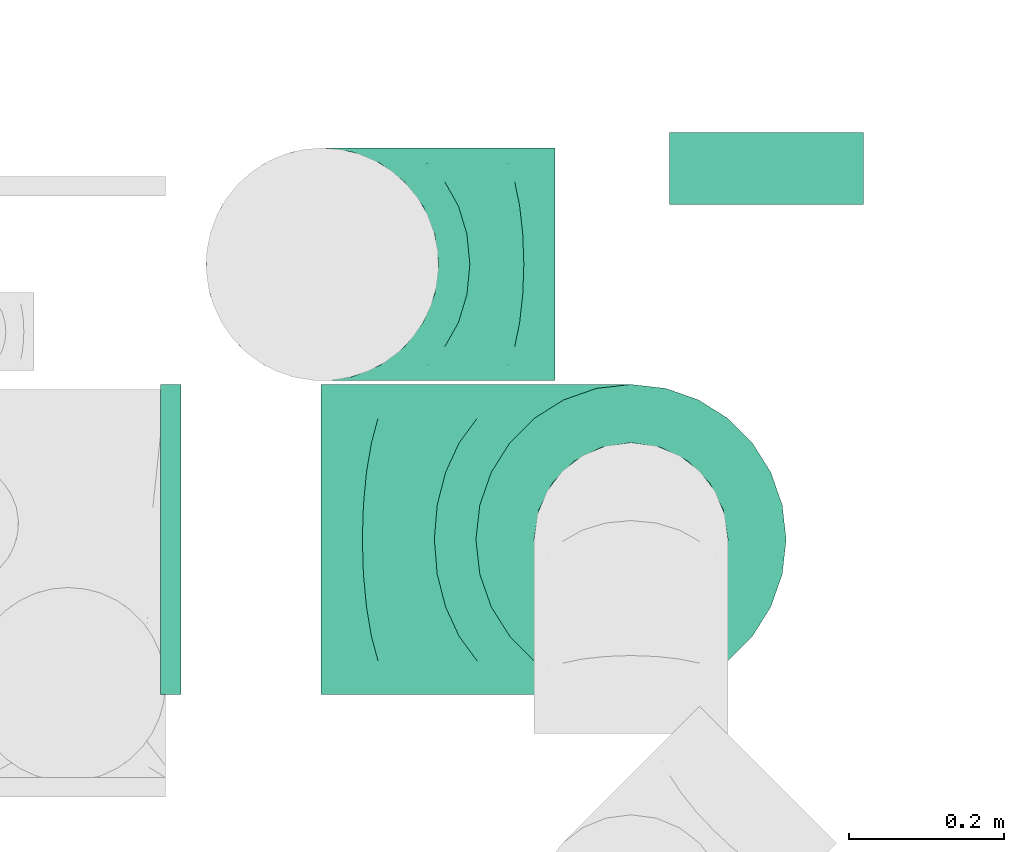
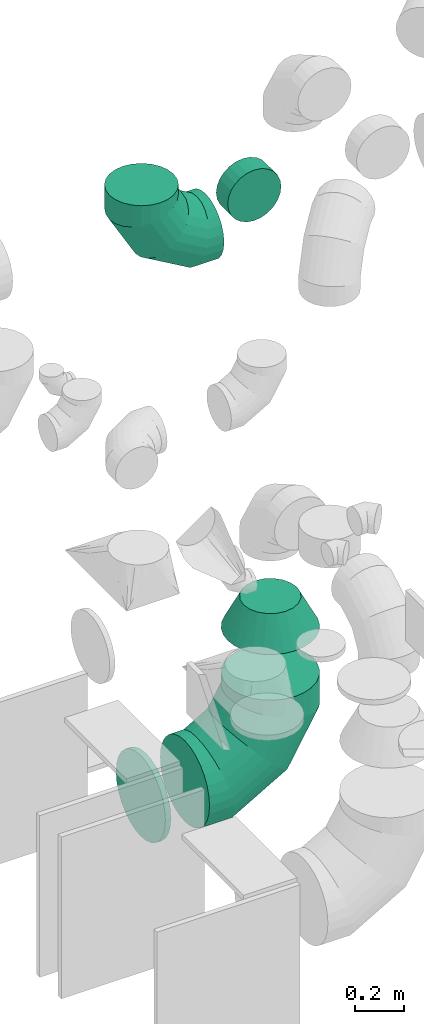
# One storey, part 34 of 59: 5 flow fittings.
"""IFC2X3 building model written with IfcOpenShell, lengths in millimetres."""

from ifc_helpers import new_model, entity, si_unit, converted_unit, derived_unit, direction, frame, origin, place, context, subcontext, project, spatial, faceted_brep, source, transform, mapped, material, type_object, type_shapes, element, save


model = new_model("IFC2X3")

# Units and contexts
model_context = context("Model", 3, precision=0.01, world=origin(), true_north=direction((6.12303176911189e-17, 1.0)))
body_context = subcontext(model_context, "Body", "Model", "MODEL_VIEW")
ifc_project = project(units=[si_unit("LENGTHUNIT", "METRE", prefix="MILLI"), si_unit("AREAUNIT", "SQUARE_METRE"), si_unit("VOLUMEUNIT", "CUBIC_METRE"), converted_unit("PLANEANGLEUNIT", "DEGREE", entity("IfcRatioMeasure", 0.0174532925199433), si_unit("PLANEANGLEUNIT", "RADIAN"), dimensions=[0, 0, 0, 0, 0, 0, 0]), si_unit("MASSUNIT", "GRAM", prefix="KILO"), derived_unit("MASSDENSITYUNIT", [(si_unit("MASSUNIT", "GRAM", prefix="KILO"), 1), (si_unit("LENGTHUNIT", "METRE"), -3)]), derived_unit("MOMENTOFINERTIAUNIT", [(si_unit("LENGTHUNIT", "METRE"), 4)]), si_unit("TIMEUNIT", "SECOND"), si_unit("FREQUENCYUNIT", "HERTZ"), si_unit("THERMODYNAMICTEMPERATUREUNIT", "DEGREE_CELSIUS"), derived_unit("THERMALTRANSMITTANCEUNIT", [(si_unit("MASSUNIT", "GRAM", prefix="KILO"), 1), (si_unit("THERMODYNAMICTEMPERATUREUNIT", "KELVIN"), -1), (si_unit("TIMEUNIT", "SECOND"), -3)]), derived_unit("VOLUMETRICFLOWRATEUNIT", [(si_unit("LENGTHUNIT", "METRE"), 3), (si_unit("TIMEUNIT", "SECOND"), -1)]), derived_unit("MASSFLOWRATEUNIT", [(si_unit("MASSUNIT", "GRAM", prefix="KILO"), 1), (si_unit("TIMEUNIT", "SECOND"), -1)]), derived_unit("ROTATIONALFREQUENCYUNIT", [(si_unit("TIMEUNIT", "SECOND"), -1)]), si_unit("ELECTRICCURRENTUNIT", "AMPERE"), si_unit("ELECTRICVOLTAGEUNIT", "VOLT"), si_unit("POWERUNIT", "WATT"), si_unit("FORCEUNIT", "NEWTON", prefix="KILO"), si_unit("ILLUMINANCEUNIT", "LUX"), si_unit("LUMINOUSFLUXUNIT", "LUMEN"), si_unit("LUMINOUSINTENSITYUNIT", "CANDELA"), derived_unit("USERDEFINED", [(si_unit("MASSUNIT", "GRAM", prefix="KILO"), -1), (si_unit("LENGTHUNIT", "METRE"), -2), (si_unit("TIMEUNIT", "SECOND"), 3), (si_unit("LUMINOUSFLUXUNIT", "LUMEN"), 1)]), derived_unit("LINEARVELOCITYUNIT", [(si_unit("LENGTHUNIT", "METRE"), 1), (si_unit("TIMEUNIT", "SECOND"), -1)]), si_unit("PRESSUREUNIT", "PASCAL"), derived_unit("USERDEFINED", [(si_unit("LENGTHUNIT", "METRE"), -2), (si_unit("MASSUNIT", "GRAM", prefix="KILO"), 1), (si_unit("TIMEUNIT", "SECOND"), -2)]), derived_unit("LINEARFORCEUNIT", [(si_unit("MASSUNIT", "GRAM", prefix="KILO"), 1), (si_unit("LENGTHUNIT", "METRE"), 1), (si_unit("TIMEUNIT", "SECOND"), -2), (si_unit("LENGTHUNIT", "METRE"), -1)]), derived_unit("PLANARFORCEUNIT", [(si_unit("MASSUNIT", "GRAM", prefix="KILO"), 1), (si_unit("LENGTHUNIT", "METRE"), 1), (si_unit("TIMEUNIT", "SECOND"), -2), (si_unit("LENGTHUNIT", "METRE"), -2)])], contexts=[model_context])

# Site, building, storey
site_placement = place(None, origin())
site = spatial("IfcSite", under=ifc_project, at=site_placement, CompositionType="ELEMENT")
building_placement = place(site_placement, origin())
building = spatial("IfcBuilding", under=site, at=building_placement, CompositionType="ELEMENT")
storey_placement = place(building_placement, frame((0.0, 0.0, 28200.0)))
storey = spatial("IfcBuildingStorey", under=building, at=storey_placement, CompositionType="ELEMENT", Elevation=28200.0)

# Flow fittings
ifc_material = material()
duct_fitting_type_1 = type_object("IfcDuctFittingType", PredefinedType="NOTDEFINED", material=ifc_material)
shared_shape_1 = source(origin(), body_context, "Body", "Brep", [
    faceted_brep([(-400.0, 0.0, -200.0), (-400.0, -44.5, -194.99), (-400.0, -86.78, -180.19), (-400.0, -124.7, -156.37), (-400.0, -156.37, -124.7), (-400.0, -180.19, -86.78), (-400.0, -194.99, -44.5), (-400.0, -200.0, 0.0), (-400.0, -194.99, 44.5), (-400.0, -180.19, 86.78), (-400.0, -156.37, 124.7), (-400.0, -124.7, 156.37), (-400.0, -86.78, 180.19), (-400.0, -44.5, 194.99), (-400.0, 0.0, 200.0), (-400.0, 44.5, 194.99), (-400.0, 86.78, 180.19), (-400.0, 124.7, 156.37), (-400.0, 156.37, 124.7), (-400.0, 180.19, 86.78), (-400.0, 194.99, 44.5), (-400.0, 200.0, 0.0), (-400.0, 194.99, -44.5), (-400.0, 180.19, -86.78), (-400.0, 156.37, -124.7), (-400.0, 124.7, -156.37), (-400.0, 86.78, -180.19), (-400.0, 44.5, -194.99), (-292.82, 0.0, 200.0), (-304.75, 44.5, 194.99), (-316.07, 86.78, 180.19), (-326.23, 124.7, 156.37), (-334.72, 156.37, 124.7), (-341.1, 180.19, 86.78), (-345.07, 194.99, 44.5), (-346.41, 200.0, 0.0), (-345.07, 194.99, -44.5), (-341.1, 180.19, -86.78), (-334.72, 156.37, -124.7), (-326.23, 124.7, -156.37), (-316.07, 86.78, -180.19), (-304.75, 44.5, -194.99), (-292.82, 0.0, -200.0), (-280.9, -44.5, -194.99), (-269.57, -86.78, -180.19), (-259.41, -124.7, -156.37), (-250.92, -156.37, -124.7), (-244.54, -180.19, -86.78), (-240.57, -194.99, -44.5), (-239.23, -200.0, 0.0), (-240.57, -194.99, 44.5), (-244.54, -180.19, 86.78), (-250.92, -156.37, 124.7), (-259.41, -124.7, 156.37), (-269.57, -86.78, 180.19), (-280.9, -44.5, 194.99), (-107.18, 107.18, 200.0), (-139.76, 139.76, 194.99), (-170.7, 170.7, 180.19), (-198.46, 198.46, 156.37), (-221.65, 221.65, 124.7), (-239.09, 239.09, 86.78), (-249.92, 249.92, 44.5), (-253.59, 253.59, 0.0), (-249.92, 249.92, -44.5), (-239.09, 239.09, -86.78), (-221.65, 221.65, -124.7), (-198.46, 198.46, -156.37), (-170.7, 170.7, -180.19), (-139.76, 139.76, -194.99), (-107.18, 107.18, -200.0), (-74.6, 74.6, -194.99), (-43.65, 43.65, -180.19), (-15.89, 15.89, -156.37), (7.29, -7.29, -124.7), (24.73, -24.73, -86.78), (35.56, -35.56, -44.5), (39.23, -39.23, 0.0), (35.56, -35.56, 44.5), (24.73, -24.73, 86.78), (7.29, -7.29, 124.7), (-15.89, 15.89, 156.37), (-43.65, 43.65, 180.19), (-74.6, 74.6, 194.99), (0.0, 292.82, 200.0), (-44.5, 304.75, 194.99), (-86.78, 316.07, 180.19), (-124.7, 326.23, 156.37), (-156.37, 334.72, 124.7), (-180.19, 341.1, 86.78), (-194.99, 345.07, 44.5), (-200.0, 346.41, 0.0), (-194.99, 345.07, -44.5), (-180.19, 341.1, -86.78), (-156.37, 334.72, -124.7), (-124.7, 326.23, -156.37), (-86.78, 316.07, -180.19), (-44.5, 304.75, -194.99), (0.0, 292.82, -200.0), (44.5, 280.9, -194.99), (86.78, 269.57, -180.19), (124.7, 259.41, -156.37), (156.37, 250.92, -124.7), (180.19, 244.54, -86.78), (194.99, 240.57, -44.5), (200.0, 239.23, 0.0), (194.99, 240.57, 44.5), (180.19, 244.54, 86.78), (156.37, 250.92, 124.7), (124.7, 259.41, 156.37), (86.78, 269.57, 180.19), (44.5, 280.9, 194.99), (-44.5, 400.0, -194.99), (-86.78, 400.0, -180.19), (-124.7, 400.0, -156.37), (-156.37, 400.0, -124.7), (-180.19, 400.0, -86.78), (-194.99, 400.0, -44.5), (-200.0, 400.0, 0.0), (-194.99, 400.0, 44.5), (-180.19, 400.0, 86.78), (-156.37, 400.0, 124.7), (-124.7, 400.0, 156.37), (-86.78, 400.0, 180.19), (-44.5, 400.0, 194.99), (0.0, 400.0, 200.0), (44.5, 400.0, 194.99), (86.78, 400.0, 180.19), (124.7, 400.0, 156.37), (156.37, 400.0, 124.7), (180.19, 400.0, 86.78), (194.99, 400.0, 44.5), (200.0, 400.0, 0.0), (194.99, 400.0, -44.5), (180.19, 400.0, -86.78), (156.37, 400.0, -124.7), (124.7, 400.0, -156.37), (86.78, 400.0, -180.19), (44.5, 400.0, -194.99), (0.0, 400.0, -200.0)], [[[0, 1, 2, 3, 4, 5, 6, 7, 8, 9, 10, 11, 12, 13, 14, 15, 16, 17, 18, 19, 20, 21, 22, 23, 24, 25, 26, 27]], [[28, 29, 15, 14]], [[30, 31, 17, 16]], [[29, 30, 16, 15]], [[31, 32, 18, 17]], [[32, 33, 19, 18]], [[34, 35, 21, 20]], [[33, 34, 20, 19]], [[35, 36, 22, 21]], [[37, 38, 24, 23]], [[36, 37, 23, 22]], [[38, 39, 25, 24]], [[39, 40, 26, 25]], [[41, 42, 0, 27]], [[40, 41, 27, 26]], [[1, 0, 42, 43]], [[43, 44, 2, 1]], [[45, 3, 2, 44]], [[45, 46, 4, 3]], [[5, 4, 46, 47]], [[47, 48, 6, 5]], [[49, 7, 6, 48]], [[7, 49, 50, 8]], [[8, 50, 51, 9]], [[9, 51, 52, 10]], [[52, 53, 11, 10]], [[11, 53, 54, 12]], [[12, 54, 55, 13]], [[13, 55, 28, 14]], [[56, 57, 29, 28]], [[58, 59, 31, 30]], [[57, 58, 30, 29]], [[59, 60, 32, 31]], [[60, 61, 33, 32]], [[62, 63, 35, 34]], [[61, 62, 34, 33]], [[63, 64, 36, 35]], [[65, 66, 38, 37]], [[64, 65, 37, 36]], [[66, 67, 39, 38]], [[67, 68, 40, 39]], [[69, 70, 42, 41]], [[68, 69, 41, 40]], [[43, 42, 70, 71]], [[71, 72, 44, 43]], [[73, 45, 44, 72]], [[73, 74, 46, 45]], [[47, 46, 74, 75]], [[75, 76, 48, 47]], [[77, 49, 48, 76]], [[50, 49, 77, 78]], [[51, 50, 78, 79]], [[52, 51, 79, 80]], [[80, 81, 53, 52]], [[54, 53, 81, 82]], [[55, 54, 82, 83]], [[28, 55, 83, 56]], [[84, 85, 57, 56]], [[86, 87, 59, 58]], [[85, 86, 58, 57]], [[87, 88, 60, 59]], [[88, 89, 61, 60]], [[90, 91, 63, 62]], [[89, 90, 62, 61]], [[91, 92, 64, 63]], [[93, 94, 66, 65]], [[92, 93, 65, 64]], [[94, 95, 67, 66]], [[95, 96, 68, 67]], [[97, 98, 70, 69]], [[96, 97, 69, 68]], [[71, 70, 98, 99]], [[99, 100, 72, 71]], [[101, 73, 72, 100]], [[101, 102, 74, 73]], [[75, 74, 102, 103]], [[103, 104, 76, 75]], [[105, 77, 76, 104]], [[78, 77, 105, 106]], [[79, 78, 106, 107]], [[80, 79, 107, 108]], [[108, 109, 81, 80]], [[82, 81, 109, 110]], [[83, 82, 110, 111]], [[56, 83, 111, 84]], [[112, 113, 114, 115, 116, 117, 118, 119, 120, 121, 122, 123, 124, 125, 126, 127, 128, 129, 130, 131, 132, 133, 134, 135, 136, 137, 138, 139]], [[85, 84, 125, 124]], [[86, 85, 124, 123]], [[87, 86, 123, 122]], [[122, 121, 88, 87]], [[89, 88, 121, 120]], [[90, 89, 120, 119]], [[91, 90, 119, 118]], [[91, 118, 117, 92]], [[92, 117, 116, 93]], [[93, 116, 115, 94]], [[115, 114, 95, 94]], [[95, 114, 113, 96]], [[96, 113, 112, 97]], [[97, 112, 139, 98]], [[98, 139, 138, 99]], [[99, 138, 137, 100]], [[100, 137, 136, 101]], [[136, 135, 102, 101]], [[102, 135, 134, 103]], [[103, 134, 133, 104]], [[104, 133, 132, 105]], [[106, 105, 132, 131]], [[107, 106, 131, 130]], [[108, 107, 130, 129]], [[129, 128, 109, 108]], [[110, 109, 128, 127]], [[111, 110, 127, 126]], [[84, 111, 126, 125]]]),
])
type_shapes(duct_fitting_type_1, [shared_shape_1])
flow_fitting_1_placement = place(storey_placement, frame((56320.5, 11837.37, 665.0), z_axis=(0.0, 1.0, 0.0), x_axis=(0.0, 0.0, -1.0)))
element("IfcFlowFitting", 1, at=flow_fitting_1_placement, inside=storey, type_object=duct_fitting_type_1, material=ifc_material, context=body_context, shape_type="MappedRepresentation", body=[
    mapped(shared_shape_1, transform((0.0, 0.0, 0.0), scale=1.0)),
])
duct_fitting_type_2 = type_object("IfcDuctFittingType", PredefinedType="NOTDEFINED", material=ifc_material)
shared_shape_2 = source(origin(), body_context, "Body", "Brep", [
    faceted_brep([(-300.0, 0.0, -150.0), (-300.0, -38.82, -144.89), (-300.0, -75.0, -129.9), (-300.0, -106.07, -106.07), (-300.0, -129.9, -75.0), (-300.0, -144.89, -38.82), (-300.0, -150.0, 0.0), (-300.0, -144.89, 38.82), (-300.0, -129.9, 75.0), (-300.0, -106.07, 106.07), (-300.0, -75.0, 129.9), (-300.0, -38.82, 144.89), (-300.0, 0.0, 150.0), (-300.0, 38.82, 144.89), (-300.0, 75.0, 129.9), (-300.0, 106.07, 106.07), (-300.0, 129.9, 75.0), (-300.0, 144.89, 38.82), (-300.0, 150.0, 0.0), (-300.0, 144.89, -38.82), (-300.0, 129.9, -75.0), (-300.0, 106.07, -106.07), (-300.0, 75.0, -129.9), (-300.0, 38.82, -144.89), (-230.02, 38.82, 144.89), (-239.71, 75.0, 129.9), (-219.62, 0.0, 150.0), (-248.04, 106.07, 106.07), (-258.44, 144.89, 38.82), (-259.81, 150.0, 0.0), (-254.42, 129.9, 75.0), (-254.42, 129.9, -75.0), (-248.04, 106.07, -106.07), (-258.44, 144.89, -38.82), (-230.02, 38.82, -144.89), (-219.62, 0.0, -150.0), (-239.71, 75.0, -129.9), (-209.21, -38.82, -144.89), (-199.52, -75.0, -129.9), (-191.19, -106.07, -106.07), (-184.81, -129.9, -75.0), (-180.79, -144.89, -38.82), (-179.42, -150.0, 0.0), (-180.79, -144.89, 38.82), (-184.81, -129.9, 75.0), (-191.19, -106.07, 106.07), (-199.52, -75.0, 129.9), (-209.21, -38.82, 144.89), (-108.81, 108.81, 144.89), (-135.29, 135.29, 129.9), (-80.38, 80.38, 150.0), (-158.03, 158.03, 106.07), (-175.48, 175.48, 75.0), (-186.45, 186.45, 38.82), (-190.19, 190.19, 0.0), (-186.45, 186.45, -38.82), (-175.48, 175.48, -75.0), (-158.03, 158.03, -106.07), (-108.81, 108.81, -144.89), (-80.38, 80.38, -150.0), (-135.29, 135.29, -129.9), (-51.96, 51.96, -144.89), (-25.48, 25.48, -129.9), (-2.74, 2.74, -106.07), (14.71, -14.71, -75.0), (25.68, -25.68, -38.82), (29.42, -29.42, 0.0), (25.68, -25.68, 38.82), (14.71, -14.71, 75.0), (-2.74, 2.74, 106.07), (-25.48, 25.48, 129.9), (-51.96, 51.96, 144.89), (-38.82, 230.02, 144.89), (-75.0, 239.71, 129.9), (0.0, 219.62, 150.0), (-106.07, 248.04, 106.07), (-129.9, 254.42, 75.0), (-144.89, 258.44, 38.82), (-150.0, 259.81, 0.0), (-144.89, 258.44, -38.82), (-129.9, 254.42, -75.0), (-106.07, 248.04, -106.07), (-38.82, 230.02, -144.89), (0.0, 219.62, -150.0), (-75.0, 239.71, -129.9), (38.82, 209.21, -144.89), (75.0, 199.52, -129.9), (106.07, 191.19, -106.07), (129.9, 184.81, -75.0), (144.89, 180.79, -38.82), (150.0, 179.42, 0.0), (144.89, 180.79, 38.82), (129.9, 184.81, 75.0), (106.07, 191.19, 106.07), (75.0, 199.52, 129.9), (38.82, 209.21, 144.89), (-150.0, 300.0, 0.0), (-144.89, 300.0, 38.82), (-129.9, 300.0, 75.0), (-106.07, 300.0, 106.07), (-75.0, 300.0, 129.9), (-38.82, 300.0, 144.89), (0.0, 300.0, 150.0), (38.82, 300.0, 144.89), (75.0, 300.0, 129.9), (106.07, 300.0, 106.07), (129.9, 300.0, 75.0), (144.89, 300.0, 38.82), (150.0, 300.0, 0.0), (144.89, 300.0, -38.82), (129.9, 300.0, -75.0), (106.07, 300.0, -106.07), (75.0, 300.0, -129.9), (38.82, 300.0, -144.89), (0.0, 300.0, -150.0), (-38.82, 300.0, -144.89), (-75.0, 300.0, -129.9), (-106.07, 300.0, -106.07), (-129.9, 300.0, -75.0), (-144.89, 300.0, -38.82)], [[[0, 1, 2, 3, 4, 5, 6, 7, 8, 9, 10, 11, 12, 13, 14, 15, 16, 17, 18, 19, 20, 21, 22, 23]], [[24, 25, 14, 13]], [[26, 24, 13, 12]], [[14, 25, 27, 15]], [[28, 29, 18, 17]], [[30, 28, 17, 16]], [[15, 27, 30, 16]], [[20, 31, 32, 21]], [[33, 31, 20, 19]], [[18, 29, 33, 19]], [[34, 35, 0, 23]], [[36, 34, 23, 22]], [[32, 36, 22, 21]], [[1, 0, 35, 37]], [[2, 1, 37, 38]], [[38, 39, 3, 2]], [[5, 4, 40, 41]], [[6, 5, 41, 42]], [[39, 40, 4, 3]], [[6, 42, 43, 7]], [[7, 43, 44, 8]], [[8, 44, 45, 9]], [[9, 45, 46, 10]], [[10, 46, 47, 11]], [[26, 12, 11, 47]], [[48, 49, 25, 24]], [[50, 48, 24, 26]], [[27, 25, 49, 51]], [[52, 53, 28, 30]], [[51, 52, 30, 27]], [[29, 28, 53, 54]], [[55, 56, 31, 33]], [[54, 55, 33, 29]], [[32, 31, 56, 57]], [[58, 59, 35, 34]], [[60, 58, 34, 36]], [[57, 60, 36, 32]], [[37, 35, 59, 61]], [[38, 37, 61, 62]], [[39, 38, 62, 63]], [[41, 40, 64, 65]], [[42, 41, 65, 66]], [[63, 64, 40, 39]], [[43, 42, 66, 67]], [[44, 43, 67, 68]], [[68, 69, 45, 44]], [[46, 45, 69, 70]], [[47, 46, 70, 71]], [[26, 47, 71, 50]], [[72, 73, 49, 48]], [[74, 72, 48, 50]], [[51, 49, 73, 75]], [[76, 77, 53, 52]], [[75, 76, 52, 51]], [[54, 53, 77, 78]], [[79, 80, 56, 55]], [[78, 79, 55, 54]], [[57, 56, 80, 81]], [[82, 83, 59, 58]], [[84, 82, 58, 60]], [[81, 84, 60, 57]], [[61, 59, 83, 85]], [[62, 61, 85, 86]], [[63, 62, 86, 87]], [[65, 64, 88, 89]], [[66, 65, 89, 90]], [[87, 88, 64, 63]], [[67, 66, 90, 91]], [[68, 67, 91, 92]], [[92, 93, 69, 68]], [[70, 69, 93, 94]], [[71, 70, 94, 95]], [[50, 71, 95, 74]], [[96, 97, 98, 99, 100, 101, 102, 103, 104, 105, 106, 107, 108, 109, 110, 111, 112, 113, 114, 115, 116, 117, 118, 119]], [[101, 100, 73, 72]], [[102, 101, 72, 74]], [[75, 73, 100, 99]], [[77, 76, 98, 97]], [[78, 77, 97, 96]], [[99, 98, 76, 75]], [[119, 118, 80, 79]], [[96, 119, 79, 78]], [[117, 81, 80, 118]], [[84, 116, 115, 82]], [[82, 115, 114, 83]], [[116, 84, 81, 117]], [[83, 114, 113, 85]], [[85, 113, 112, 86]], [[111, 87, 86, 112]], [[88, 110, 109, 89]], [[89, 109, 108, 90]], [[110, 88, 87, 111]], [[91, 90, 108, 107]], [[92, 91, 107, 106]], [[106, 105, 93, 92]], [[95, 94, 104, 103]], [[74, 95, 103, 102]], [[105, 104, 94, 93]]]),
])
type_shapes(duct_fitting_type_2, [shared_shape_2])
flow_fitting_2_placement = place(storey_placement, frame((55922.5, 12192.32, 3100.0), z_axis=(0.0, 1.0, 0.0), x_axis=(-1.0, 0.0, 0.0)))
element("IfcFlowFitting", 2, at=flow_fitting_2_placement, inside=storey, type_object=duct_fitting_type_2, material=ifc_material, context=body_context, shape_type="MappedRepresentation", body=[
    mapped(shared_shape_2, transform((0.0, 0.0, 0.0), scale=1.0)),
])
duct_fitting_type_3 = type_object("IfcDuctFittingType", PredefinedType="NOTDEFINED", material=ifc_material)
shared_shape_3 = source(origin(), body_context, "Body", "Brep", [
    faceted_brep([(150.0, -86.78, -180.19), (150.0, -44.5, -194.99), (150.0, 0.0, -200.0), (150.0, 44.5, -194.99), (150.0, 86.78, -180.19), (150.0, 124.7, -156.37), (150.0, 156.37, -124.7), (150.0, 180.19, -86.78), (150.0, 194.99, -44.5), (150.0, 200.0, 0.0), (150.0, 194.99, 44.5), (150.0, 180.19, 86.78), (150.0, 156.37, 124.7), (150.0, 124.7, 156.37), (150.0, 86.78, 180.19), (150.0, 44.5, 194.99), (150.0, 0.0, 200.0), (150.0, -44.5, 194.99), (150.0, -86.78, 180.19), (150.0, -124.7, 156.37), (150.0, -156.37, 124.7), (150.0, -180.19, 86.78), (150.0, -194.99, 44.5), (150.0, -200.0, 0.0), (150.0, -194.99, -44.5), (150.0, -180.19, -86.78), (150.0, -156.37, -124.7), (150.0, -124.7, -156.37), (0.0, 38.63, -118.88), (0.0, 0.0, -125.0), (0.0, -38.63, -118.88), (0.0, -73.47, -101.13), (0.0, -101.13, -73.47), (0.0, -118.88, -38.63), (0.0, -125.0, 0.0), (0.0, -118.88, 38.63), (0.0, -101.13, 73.47), (0.0, -73.47, 101.13), (0.0, -38.63, 118.88), (0.0, 0.0, 125.0), (0.0, 38.63, 118.88), (0.0, 73.47, 101.13), (0.0, 101.13, 73.47), (0.0, 118.88, 38.63), (0.0, 125.0, 0.0), (0.0, 118.88, -38.63), (0.0, 101.13, -73.47), (0.0, 73.47, -101.13)], [[[0, 1, 2, 3, 4, 5, 6, 7, 8, 9, 10, 11, 12, 13, 14, 15, 16, 17, 18, 19, 20, 21, 22, 23, 24, 25, 26, 27]], [[28, 29, 30, 31, 32, 33, 34, 35, 36, 37, 38, 39, 40, 41, 42, 43, 44, 45, 46, 47]], [[10, 44, 43]], [[11, 43, 42]], [[10, 9, 44]], [[12, 11, 42]], [[10, 43, 11]], [[42, 41, 13, 12]], [[40, 39, 15]], [[41, 40, 14]], [[13, 41, 14]], [[14, 40, 15]], [[39, 16, 15]], [[17, 39, 38]], [[18, 38, 37]], [[17, 16, 39]], [[19, 18, 37]], [[17, 38, 18]], [[37, 36, 20, 19]], [[35, 34, 22]], [[36, 35, 21]], [[20, 36, 21]], [[21, 35, 22]], [[34, 23, 22]], [[24, 34, 33]], [[25, 33, 32]], [[24, 23, 34]], [[26, 25, 32]], [[24, 33, 25]], [[32, 31, 27, 26]], [[30, 29, 1]], [[31, 30, 0]], [[27, 31, 0]], [[0, 30, 1]], [[29, 2, 1]], [[3, 29, 28]], [[4, 28, 47]], [[3, 2, 29]], [[5, 4, 47]], [[3, 28, 4]], [[47, 46, 6, 5]], [[45, 44, 8]], [[46, 45, 7]], [[6, 46, 7]], [[7, 45, 8]], [[44, 9, 8]]]),
])
type_shapes(duct_fitting_type_3, [shared_shape_3])
flow_fitting_3_placement = place(storey_placement, frame((56320.5, 11837.37, 1440.82), z_axis=(0.0, -1.0, 0.0), x_axis=(0.0, 0.0, -1.0)))
element("IfcFlowFitting", 3, at=flow_fitting_3_placement, inside=storey, type_object=duct_fitting_type_3, material=ifc_material, context=body_context, shape_type="MappedRepresentation", body=[
    mapped(shared_shape_3, transform((0.0, 0.0, 0.0), scale=1.0)),
])
duct_fitting_type_4 = type_object("IfcDuctFittingType", PredefinedType="NOTDEFINED", material=ifc_material)
shared_shape_4 = source(origin(), body_context, "Body", "Brep", [
    faceted_brep([(20.0, 0.0, -200.0), (20.0, 44.5, -194.99), (20.0, 86.78, -180.19), (20.0, 124.7, -156.37), (20.0, 156.37, -124.7), (20.0, 180.19, -86.78), (20.0, 194.99, -44.5), (20.0, 200.0, 0.0), (20.0, 194.99, 44.5), (20.0, 180.19, 86.78), (20.0, 156.37, 124.7), (20.0, 124.7, 156.37), (20.0, 86.78, 180.19), (20.0, 44.5, 194.99), (20.0, 0.0, 200.0), (20.0, -44.5, 194.99), (20.0, -86.78, 180.19), (20.0, -124.7, 156.37), (20.0, -156.37, 124.7), (20.0, -180.19, 86.78), (20.0, -194.99, 44.5), (20.0, -200.0, 0.0), (20.0, -194.99, -44.5), (20.0, -180.19, -86.78), (20.0, -156.37, -124.7), (20.0, -124.7, -156.37), (20.0, -86.78, -180.19), (20.0, -44.5, -194.99), (0.0, 0.0, 200.0), (0.0, -30.6, 196.55), (0.0, -44.5, 194.99), (-6.1, -22.25, 197.49), (-6.1, 0.0, 200.0), (-6.1, -44.5, 194.99), (0.0, -65.64, 187.59), (-6.1, -65.64, 187.59), (0.0, -86.78, 180.19), (-6.1, -86.78, 180.19), (0.0, -105.74, 168.28), (-6.1, -105.74, 168.28), (0.0, -124.7, 156.37), (-6.1, -124.7, 156.37), (0.0, -140.53, 140.53), (-6.1, -140.53, 140.53), (0.0, -156.37, 124.7), (-6.1, -156.37, 124.7), (0.0, -168.28, 105.74), (0.0, -180.19, 86.78), (-6.1, -168.28, 105.74), (-6.1, -180.19, 86.78), (0.0, -187.59, 65.64), (-6.1, -187.59, 65.64), (0.0, -194.99, 44.5), (-6.1, -194.99, 44.5), (0.0, -197.49, 22.25), (-6.1, -196.55, 30.6), (-6.1, -200.0, 0.0), (0.0, -200.0, 0.0), (0.0, -196.55, -30.6), (0.0, -194.99, -44.5), (-6.1, -197.49, -22.25), (-6.1, -194.99, -44.5), (0.0, -187.59, -65.64), (-6.1, -187.59, -65.64), (0.0, -180.19, -86.78), (-6.1, -180.19, -86.78), (0.0, -168.28, -105.74), (-6.1, -168.28, -105.74), (0.0, -156.37, -124.7), (-6.1, -156.37, -124.7), (0.0, -140.53, -140.53), (-6.1, -140.53, -140.53), (0.0, -124.7, -156.37), (-6.1, -124.7, -156.37), (0.0, -105.74, -168.28), (-6.1, -105.74, -168.28), (-6.1, -86.78, -180.19), (0.0, -86.78, -180.19), (0.0, -44.5, -194.99), (0.0, -65.64, -187.59), (-6.1, -44.5, -194.99), (-6.1, -65.64, -187.59), (0.0, 0.0, -200.0), (0.0, -30.6, -196.55), (-6.1, -22.25, -197.49), (-6.1, 0.0, -200.0), (0.0, 30.6, -196.55), (0.0, 44.5, -194.99), (-6.1, 22.25, -197.49), (-6.1, 44.5, -194.99), (0.0, 65.64, -187.59), (-6.1, 65.64, -187.59), (0.0, 86.78, -180.19), (-6.1, 86.78, -180.19), (0.0, 105.74, -168.28), (-6.1, 105.74, -168.28), (0.0, 124.7, -156.37), (-6.1, 124.7, -156.37), (0.0, 140.53, -140.53), (-6.1, 140.53, -140.53), (0.0, 156.37, -124.7), (-6.1, 156.37, -124.7), (0.0, 168.28, -105.74), (-6.1, 168.28, -105.74), (0.0, 180.19, -86.78), (-6.1, 180.19, -86.78), (0.0, 194.99, -44.5), (0.0, 196.55, -30.6), (-6.1, 194.99, -44.5), (-6.1, 197.49, -22.25), (0.0, 200.0, 0.0), (-6.1, 200.0, 0.0), (0.0, 187.59, -65.64), (-6.1, 187.59, -65.64), (0.0, 196.55, 30.6), (0.0, 194.99, 44.5), (-6.1, 197.49, 22.25), (-6.1, 194.99, 44.5), (0.0, 187.59, 65.64), (-6.1, 187.59, 65.64), (0.0, 180.19, 86.78), (-6.1, 180.19, 86.78), (0.0, 168.28, 105.74), (-6.1, 168.28, 105.74), (0.0, 156.37, 124.7), (-6.1, 156.37, 124.7), (0.0, 140.53, 140.53), (-6.1, 140.53, 140.53), (0.0, 124.7, 156.37), (-6.1, 124.7, 156.37), (0.0, 105.74, 168.28), (0.0, 86.78, 180.19), (-6.1, 105.74, 168.28), (-6.1, 86.78, 180.19), (0.0, 65.64, 187.59), (-6.1, 65.64, 187.59), (0.0, 44.5, 194.99), (-6.1, 44.5, 194.99), (0.0, 22.25, 197.49), (-6.1, 30.6, 196.55)], [[[0, 1, 2, 3, 4, 5, 6, 7, 8, 9, 10, 11, 12, 13, 14, 15, 16, 17, 18, 19, 20, 21, 22, 23, 24, 25, 26, 27]], [[15, 14, 28]], [[15, 28, 29]], [[15, 29, 30]], [[31, 29, 28]], [[31, 28, 32]], [[31, 33, 29]], [[29, 33, 30]], [[30, 16, 15]], [[16, 30, 34]], [[30, 33, 34]], [[35, 34, 33]], [[36, 34, 35]], [[35, 37, 36]], [[16, 34, 36]], [[16, 36, 17]], [[17, 36, 38]], [[36, 37, 38]], [[39, 38, 37]], [[39, 40, 38]], [[39, 41, 40]], [[17, 38, 40]], [[40, 18, 17]], [[18, 40, 42]], [[41, 42, 40]], [[43, 42, 41]], [[44, 42, 43]], [[43, 45, 44]], [[18, 42, 44]], [[19, 18, 44]], [[19, 44, 46]], [[19, 46, 47]], [[46, 44, 45]], [[48, 46, 45]], [[46, 48, 47]], [[48, 49, 47]], [[47, 20, 19]], [[20, 47, 50]], [[47, 49, 50]], [[51, 50, 49]], [[52, 50, 51]], [[51, 53, 52]], [[20, 50, 52]], [[20, 52, 21]], [[21, 52, 54]], [[54, 52, 55]], [[53, 55, 52]], [[54, 55, 56]], [[54, 56, 57]], [[21, 54, 57]], [[22, 21, 57]], [[22, 57, 58]], [[22, 58, 59]], [[60, 58, 57]], [[60, 57, 56]], [[60, 61, 58]], [[58, 61, 59]], [[59, 23, 22]], [[23, 59, 62]], [[59, 61, 62]], [[63, 62, 61]], [[64, 62, 63]], [[63, 65, 64]], [[23, 62, 64]], [[23, 64, 24]], [[24, 64, 66]], [[64, 65, 66]], [[67, 66, 65]], [[67, 68, 66]], [[67, 69, 68]], [[24, 66, 68]], [[68, 25, 24]], [[25, 68, 70]], [[69, 70, 68]], [[71, 70, 69]], [[72, 70, 71]], [[71, 73, 72]], [[25, 70, 72]], [[72, 26, 25]], [[26, 72, 74]], [[74, 72, 73]], [[75, 74, 73]], [[74, 75, 76]], [[76, 77, 74]], [[26, 74, 77]], [[78, 27, 26]], [[26, 79, 78]], [[80, 78, 79]], [[26, 77, 79]], [[79, 77, 81]], [[76, 81, 77]], [[81, 80, 79]], [[0, 27, 82]], [[27, 83, 82]], [[27, 78, 83]], [[78, 80, 83]], [[84, 83, 80]], [[83, 84, 82]], [[84, 85, 82]], [[1, 0, 82]], [[1, 82, 86]], [[1, 86, 87]], [[88, 86, 82]], [[88, 82, 85]], [[88, 89, 86]], [[86, 89, 87]], [[87, 2, 1]], [[2, 87, 90]], [[87, 89, 90]], [[91, 90, 89]], [[92, 90, 91]], [[91, 93, 92]], [[2, 90, 92]], [[2, 92, 3]], [[3, 92, 94]], [[92, 93, 94]], [[95, 94, 93]], [[95, 96, 94]], [[95, 97, 96]], [[3, 94, 96]], [[96, 4, 3]], [[4, 96, 98]], [[97, 98, 96]], [[99, 98, 97]], [[100, 98, 99]], [[99, 101, 100]], [[4, 98, 100]], [[100, 5, 4]], [[5, 100, 102]], [[102, 100, 101]], [[103, 102, 101]], [[102, 103, 104]], [[103, 105, 104]], [[5, 102, 104]], [[106, 7, 6]], [[7, 106, 107]], [[106, 108, 107]], [[109, 107, 108]], [[107, 109, 110]], [[109, 111, 110]], [[7, 107, 110]], [[106, 6, 5]], [[5, 112, 106]], [[108, 106, 112]], [[5, 104, 112]], [[112, 104, 113]], [[105, 113, 104]], [[113, 108, 112]], [[8, 7, 110]], [[8, 110, 114]], [[8, 114, 115]], [[116, 114, 110]], [[116, 110, 111]], [[116, 117, 114]], [[114, 117, 115]], [[115, 9, 8]], [[9, 115, 118]], [[115, 117, 118]], [[119, 118, 117]], [[120, 118, 119]], [[119, 121, 120]], [[9, 118, 120]], [[9, 120, 10]], [[10, 120, 122]], [[120, 121, 122]], [[123, 122, 121]], [[123, 124, 122]], [[123, 125, 124]], [[10, 122, 124]], [[124, 11, 10]], [[11, 124, 126]], [[125, 126, 124]], [[127, 126, 125]], [[128, 126, 127]], [[127, 129, 128]], [[11, 126, 128]], [[12, 11, 128]], [[12, 128, 130]], [[12, 130, 131]], [[130, 128, 129]], [[132, 130, 129]], [[130, 132, 131]], [[132, 133, 131]], [[131, 13, 12]], [[13, 131, 134]], [[131, 133, 134]], [[135, 134, 133]], [[136, 134, 135]], [[135, 137, 136]], [[13, 134, 136]], [[13, 136, 14]], [[14, 136, 138]], [[138, 136, 139]], [[137, 139, 136]], [[138, 139, 32]], [[138, 32, 28]], [[14, 138, 28]], [[56, 55, 53, 51, 49, 48, 45, 43, 41, 39, 37, 35, 33, 31, 32, 139, 137, 135, 133, 132, 129, 127, 125, 123, 121, 119, 117, 116, 111, 109, 108, 113, 105, 103, 101, 99, 97, 95, 93, 91, 89, 88, 85, 84, 80, 81, 76, 75, 73, 71, 69, 67, 65, 63, 61, 60]]]),
])
type_shapes(duct_fitting_type_4, [shared_shape_4])
flow_fitting_4_placement = place(storey_placement, frame((55720.02, 11837.37, 665.0), z_axis=(0.0, 0.0, -1.0), x_axis=(1.0, 0.0, 0.0)))
element("IfcFlowFitting", 4, at=flow_fitting_4_placement, inside=storey, type_object=duct_fitting_type_4, material=ifc_material, context=body_context, shape_type="MappedRepresentation", body=[
    mapped(shared_shape_4, transform((0.0, 0.0, 0.0), scale=1.0)),
])
duct_fitting_type_5 = type_object("IfcDuctFittingType", PredefinedType="NOTDEFINED", material=ifc_material)
shared_shape_5 = source(origin(), body_context, "Body", "Brep", [
    faceted_brep([(20.01, 0.0, -125.0), (20.01, 32.35, -120.74), (20.01, 62.5, -108.25), (20.01, 88.39, -88.39), (20.01, 108.25, -62.5), (20.01, 120.74, -32.35), (20.01, 125.0, 0.0), (20.01, 120.74, 32.35), (20.01, 108.25, 62.5), (20.01, 88.39, 88.39), (20.01, 62.5, 108.25), (20.01, 32.35, 120.74), (20.01, 0.0, 125.0), (20.01, -32.35, 120.74), (20.01, -62.5, 108.25), (20.01, -88.39, 88.39), (20.01, -108.25, 62.5), (20.01, -120.74, 32.35), (20.01, -125.0, 0.0), (20.01, -120.74, -32.35), (20.01, -108.25, -62.5), (20.01, -88.39, -88.39), (20.01, -62.5, -108.25), (20.01, -32.35, -120.74), (0.0, 0.0, 125.0), (-73.17, 0.0, 125.0), (-73.17, -32.35, 120.74), (0.0, -32.35, 120.74), (-73.17, -62.5, 108.25), (0.0, -62.5, 108.25), (0.0, -88.39, 88.39), (-73.17, -88.39, 88.39), (0.0, -108.25, 62.5), (-73.17, -108.25, 62.5), (-73.17, -120.74, 32.35), (0.0, -120.74, 32.35), (-73.17, -125.0, 0.0), (0.0, -125.0, 0.0), (-73.17, -120.74, -32.35), (0.0, -120.74, -32.35), (-73.17, -108.25, -62.5), (0.0, -108.25, -62.5), (0.0, -88.39, -88.39), (-73.17, -88.39, -88.39), (0.0, -62.5, -108.25), (-73.17, -62.5, -108.25), (-73.17, -32.35, -120.74), (0.0, -32.35, -120.74), (-73.17, 0.0, -125.0), (0.0, 0.0, -125.0), (-73.17, 32.35, -120.74), (0.0, 32.35, -120.74), (-73.17, 62.5, -108.25), (0.0, 62.5, -108.25), (0.0, 88.39, -88.39), (-73.17, 88.39, -88.39), (0.0, 108.25, -62.5), (-73.17, 108.25, -62.5), (-73.17, 120.74, -32.35), (0.0, 120.74, -32.35), (-73.17, 125.0, 0.0), (0.0, 125.0, 0.0), (-73.17, 120.74, 32.35), (0.0, 120.74, 32.35), (-73.17, 108.25, 62.5), (0.0, 108.25, 62.5), (0.0, 88.39, 88.39), (-73.17, 88.39, 88.39), (0.0, 62.5, 108.25), (-73.17, 62.5, 108.25), (-73.17, 32.35, 120.74), (0.0, 32.35, 120.74)], [[[0, 1, 2, 3, 4, 5, 6, 7, 8, 9, 10, 11, 12, 13, 14, 15, 16, 17, 18, 19, 20, 21, 22, 23]], [[13, 12, 24, 25, 26, 27]], [[14, 13, 27, 26, 28, 29]], [[30, 15, 14, 29, 28, 31]], [[17, 16, 32, 33, 34, 35]], [[18, 17, 35, 34, 36, 37]], [[32, 16, 15, 30, 31, 33]], [[19, 18, 37, 36, 38, 39]], [[20, 19, 39, 38, 40, 41]], [[42, 21, 20, 41, 40, 43]], [[23, 22, 44, 45, 46, 47]], [[0, 23, 47, 46, 48, 49]], [[44, 22, 21, 42, 43, 45]], [[1, 0, 49, 48, 50, 51]], [[2, 1, 51, 50, 52, 53]], [[54, 3, 2, 53, 52, 55]], [[5, 4, 56, 57, 58, 59]], [[6, 5, 59, 58, 60, 61]], [[56, 4, 3, 54, 55, 57]], [[7, 6, 61, 60, 62, 63]], [[8, 7, 63, 62, 64, 65]], [[66, 9, 8, 65, 64, 67]], [[11, 10, 68, 69, 70, 71]], [[12, 11, 71, 70, 25, 24]], [[68, 10, 9, 66, 67, 69]], [[46, 45, 43, 40, 38, 36, 34, 33, 31, 28, 26, 25, 70, 69, 67, 64, 62, 60, 58, 57, 55, 52, 50, 48]]]),
])
type_shapes(duct_fitting_type_5, [shared_shape_5])
flow_fitting_5_placement = place(storey_placement, frame((56495.15, 12342.31, 3100.0), z_axis=(0.0, 0.0, -1.0), x_axis=(0.0, 1.0, 0.0)))
element("IfcFlowFitting", 5, at=flow_fitting_5_placement, inside=storey, type_object=duct_fitting_type_5, material=ifc_material, context=body_context, shape_type="MappedRepresentation", body=[
    mapped(shared_shape_5, transform((0.0, 0.0, 0.0), scale=1.0)),
])

save(model, "model.ifc")
